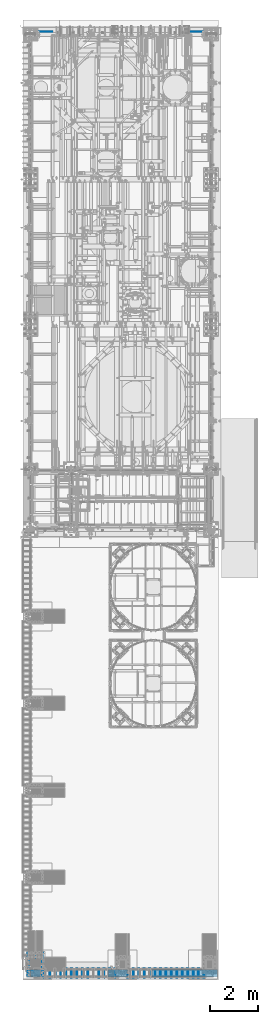
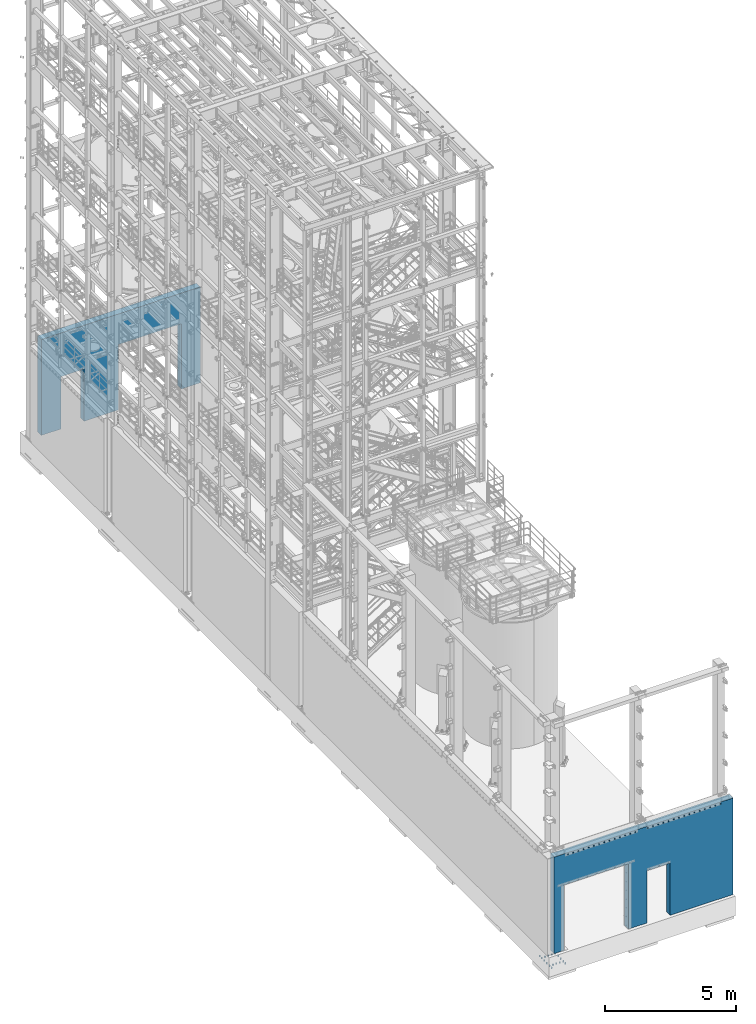
# One storey, part 1846 of 1876: 3 mechanical fasteners, 2 walls, 5 elements without a shape of their own.
"""IFC2X3 building model written with IfcOpenShell, lengths in millimetres."""

from ifc_helpers import new_model, si_unit, frame, origin_with_axes, place, context, subcontext, project, spatial, faceted_brep, source, transform, mapped, material, type_object, element, aggregate, save


model = new_model("IFC2X3")

# Units and contexts
model_context = context("Model", 3, precision=1e-05, world=origin_with_axes())
body_context = subcontext(model_context, "Body", "Model", "MODEL_VIEW")
ifc_project = project(units=[si_unit("LENGTHUNIT", "METRE", prefix="MILLI"), si_unit("AREAUNIT", "SQUARE_METRE"), si_unit("VOLUMEUNIT", "CUBIC_METRE"), si_unit("MASSUNIT", "GRAM", prefix="KILO"), si_unit("TIMEUNIT", "SECOND"), si_unit("PLANEANGLEUNIT", "RADIAN"), si_unit("SOLIDANGLEUNIT", "STERADIAN"), si_unit("THERMODYNAMICTEMPERATUREUNIT", "DEGREE_CELSIUS"), si_unit("LUMINOUSINTENSITYUNIT", "LUMEN")], contexts=[model_context])

# Site, building, storey
site_placement = place(None, origin_with_axes())
site = spatial("IfcSite", under=ifc_project, at=site_placement, CompositionType="ELEMENT")
building_placement = place(site_placement, origin_with_axes())
building = spatial("IfcBuilding", under=site, at=building_placement, Name="Undefined", CompositionType="ELEMENT")
storey_placement = place(building_placement, origin_with_axes())
storey = spatial("IfcBuildingStorey", under=building, at=storey_placement, Name="Undefined", CompositionType="ELEMENT", Elevation=0.0)

# Assembly, wall
assembly_1_placement = place(storey_placement, origin_with_axes())
assembly_1 = element("IfcElementAssembly", 1, at=assembly_1_placement, inside=storey, Name="WALL", AssemblyPlace="NOTDEFINED", PredefinedType="REINFORCEMENT_UNIT")
ifc_material_1 = material(Name="CONCRETE/5000")
wall_type_1 = type_object("IfcWallType", PredefinedType="NOTDEFINED")
wall_1_placement = place(assembly_1_placement, frame((292.100012207029, 13863.6375, 2235.2), z_axis=(0.0, 0.0, 1.0), x_axis=(1.0, 0.0, 0.0)))
wall_1 = element("IfcWall", 2, at=wall_1_placement, type_object=wall_type_1, material=ifc_material_1, Name="WALL", context=body_context, shape_type="Brep", body=[
    faceted_brep([(876.299987792969, -147.637500000001, -2235.2), (876.299987792969, 147.637500000001, -2235.2), (876.299987792969, 147.637500000001, 203.19990234375), (876.299987792969, -147.637500000001, 203.19990234375), (1892.29998779297, -147.637500000001, 203.19990234375), (1892.29998779297, 147.637500000001, 203.19990234375), (1892.29998779297, 147.637500000001, -2235.2), (1892.29998779297, -147.637500000001, -2235.2), (0.0, -147.637500000001, -2235.2), (0.0, -147.637500000001, 2235.2), (0.0, 147.637500000001, 2235.2), (0.0, 147.637500000001, -2235.2), (7010.39998779297, -147.637500000001, 2235.2), (7010.39998779297, 147.637500000001, 2235.2), (7010.39998779297, -147.637500000001, -2235.2), (7010.39998779297, 147.637500000001, -2235.2), (6170.61253662109, -147.637500000001, -2235.2), (6170.61253662109, 147.637500000001, -2235.2), (6170.61253662109, -147.637500000001, 812.8), (6170.61253662109, 147.637500000001, 812.8), (3405.18748779297, -147.637500000001, 812.8), (3405.18748779297, 147.637500000001, 812.8), (3405.18748779297, -147.637500000001, -2235.2), (3405.18748779297, 147.637500000001, -2235.2)], [[[0, 1, 2, 3]], [[4, 5, 6, 7]], [[3, 2, 5, 4]], [[8, 9, 10, 11]], [[10, 9, 12, 13]], [[12, 14, 15, 13]], [[15, 14, 16, 17]], [[18, 19, 17, 16]], [[20, 21, 19, 18]], [[22, 23, 21, 20]], [[23, 22, 7, 6]], [[1, 11, 10, 13, 15, 17, 19, 21, 23, 6, 5, 2]], [[8, 11, 1, 0]], [[22, 20, 18, 16, 14, 12, 9, 8, 0, 3, 4, 7]]]),
])
aggregate(assembly_1, [wall_1])

assembly_2_placement = place(storey_placement, origin_with_axes())
assembly_2 = element("IfcElementAssembly", 3, at=assembly_2_placement, inside=storey, Name="WALL", AssemblyPlace="NOTDEFINED", PredefinedType="REINFORCEMENT_UNIT")
wall_type_2 = type_object("IfcWallType", PredefinedType="NOTDEFINED")
wall_2_placement = place(assembly_2_placement, frame((3.17499999999995, -25776.2375, 2247.9), z_axis=(0.0, 0.0, 1.0), x_axis=(1.0, 0.0, 0.0)))
wall_2 = element("IfcWall", 4, at=wall_2_placement, type_object=wall_type_2, material=ifc_material_1, Name="WALL", context=body_context, shape_type="Brep", body=[
    faceted_brep([(4098.925, -147.637500000001, -2247.9), (4098.925, 147.637500000001, -2247.9), (4098.925, 147.637500000001, 190.49990234375), (4098.925, -147.637500000001, 190.49990234375), (5114.925, -147.637500000001, 190.49990234375), (5114.925, 147.637500000001, 190.49990234375), (5114.925, 147.637500000001, -2247.9), (5114.925, -147.637500000001, -2247.9), (3273.42504882812, -147.637500000001, 800.1), (3273.42504882812, 147.637500000001, 800.1), (3273.42504882812, 147.637500000001, -2247.9), (3273.42504882812, -147.637500000001, -2247.9), (428.625, -147.637500000001, 800.1), (428.625, 147.637500000001, 800.1), (428.625, -147.637500000001, -2247.9), (428.625, 147.637500000001, -2247.9), (0.0, -147.637500000001, -2247.9), (0.0, 147.637500000001, -2247.9), (0.0, -147.637500000001, 2247.9), (0.0, 147.637500000001, 2247.9), (7883.5248046875, -147.637500000001, 2247.9), (7883.5248046875, 147.637500000001, 2247.9), (7883.5248046875, -147.637500000001, -2247.9), (7883.5248046875, 147.637500000001, -2247.9)], [[[0, 1, 2, 3]], [[4, 5, 6, 7]], [[3, 2, 5, 4]], [[8, 9, 10, 11]], [[12, 13, 9, 8]], [[14, 15, 13, 12]], [[16, 17, 15, 14]], [[16, 18, 19, 17]], [[19, 18, 20, 21]], [[20, 22, 23, 21]], [[23, 22, 7, 6]], [[1, 10, 9, 13, 15, 17, 19, 21, 23, 6, 5, 2]], [[11, 10, 1, 0]], [[22, 20, 18, 16, 14, 12, 8, 11, 0, 3, 4, 7]]]),
])
aggregate(assembly_2, [wall_2])

# Assembly, mechanical fastener
assembly_3_placement = place(storey_placement, origin_with_axes())
assembly_3 = element("IfcElementAssembly", 5, at=assembly_3_placement, inside=storey, Name="PLATE", AssemblyPlace="NOTDEFINED", PredefinedType="RIGID_FRAME")
ifc_material_2 = material(Name="Undefined")
mechanical_fastener_type = type_object("IfcMechanicalFastenerType", Name="Bolt assembly")
shared_shape_1 = source(origin_with_axes(), body_context, "Body", "Brep", [
    faceted_brep([(16.4977843825769, -330.199999809267, 0.0), (8.24889219128843, -330.199999809267, 14.2875003814697), (-8.24889219128842, -330.199999809267, 14.2875003814697), (-16.4977843825769, -330.199999809267, 2.02039588371459e-15), (-8.24889219128844, -330.199999809267, -14.2875003814697), (8.24889219128842, -330.199999809267, -14.2875003814697), (8.24889219128842, -317.500000000001, -14.2875003814697), (-8.24889219128844, -317.500000000001, -14.2875003814697), (-16.4977843825769, -317.500000000001, 2.02039588371459e-15), (-8.24889219128842, -317.500000000001, 14.2875003814697), (8.24889219128843, -317.500000000001, 14.2875003814697), (16.4977843825769, -317.500000000001, 0.0), (9.52499961853027, -317.500000000001, 0.0), (8.24889164068414, -317.500000000001, 4.76249980926542), (4.76249980926457, -317.500000000001, 8.24889164068463), (-9.87109982941227e-13, -317.500000000001, 9.52499961853027), (-4.76249980926627, -317.500000000001, 8.24889164068365), (-8.24889164068512, -317.500000000001, 4.76249980926371), (-9.52499961853027, -317.500000000001, -1.97421996588245e-12), (-8.24889164068315, -317.500000000001, -4.76249980926713), (-4.76249980926286, -317.500000000001, -8.24889164068562), (2.95075507493764e-12, -317.500000000001, -9.52499961853027), (4.76249980926798, -317.500000000001, -8.24889164068266), (8.24889164068611, -317.500000000001, -4.76249980926201), (8.24889164068611, 38.1000007629366, -4.76249980926201), (4.76249980926798, 38.1000007629366, -8.24889164068266), (2.95075507493764e-12, 38.1000007629366, -9.52499961853027), (-4.76249980926286, 38.1000007629366, -8.24889164068562), (-8.24889164068315, 38.1000007629366, -4.76249980926713), (-9.52499961853027, 38.1000007629366, -1.97421996588245e-12), (-8.24889164068512, 38.1000007629366, 4.76249980926371), (-4.76249980926627, 38.1000007629366, 8.24889164068365), (-9.87109982941227e-13, 38.1000007629366, 9.52499961853027), (4.76249980926457, 38.1000007629366, 8.24889164068463), (8.24889164068414, 38.1000007629366, 4.76249980926542), (9.52499961853027, 38.1000007629366, 0.0), (18.6531505584717, 12.7, 0.0), (16.154102244252, 12.7, 9.3265752792364), (9.32657527923473, 12.7, 16.154102244253), (-1.93309310939524e-12, 12.7, 18.6531505584717), (-9.32657527923807, 12.7, 16.1541022442511), (-16.154102244254, 12.7, 9.32657527923306), (-18.6531505584717, 12.7, -3.86618621879047e-12), (-16.1541022442501, 12.7, -9.32657527923974), (-9.32657527923138, 12.7, -16.1541022442549), (5.77857017095389e-12, 12.7, -18.6531505584717), (9.32657527924141, 12.7, -16.1541022442491), (16.1541022442559, 12.7, -9.32657527922971), (16.1541022442559, 15.8749999523163, -9.32657527922971), (9.32657527924141, 15.8749999523163, -16.1541022442491), (5.77857017095389e-12, 15.8749999523163, -18.6531505584717), (-9.32657527923138, 15.8749999523163, -16.1541022442549), (-16.1541022442501, 15.8749999523163, -9.32657527923974), (-18.6531505584717, 15.8749999523163, -3.86618621879047e-12), (-16.154102244254, 15.8749999523163, 9.32657527923306), (-9.32657527923807, 15.8749999523163, 16.1541022442511), (-1.93309310939524e-12, 15.8749999523163, 18.6531505584717), (9.32657527923473, 15.8749999523163, 16.154102244253), (16.154102244252, 15.8749999523163, 9.3265752792364), (18.6531505584717, 15.8749999523163, 0.0), (16.4977843825769, 15.8749999523111, 0.0), (8.24889219128843, 15.8749999523111, 14.2875003814697), (-8.24889219128842, 15.8749999523111, 14.2875003814697), (-16.4977843825769, 15.8749999523111, 2.02039588371459e-15), (-8.24889219128844, 15.8749999523111, -14.2875003814697), (8.24889219128842, 15.8749999523111, -14.2875003814697), (8.24889219128842, 28.5749997615762, -14.2875003814697), (-8.24889219128844, 28.5749997615762, -14.2875003814697), (-16.4977843825769, 28.5749997615762, 2.02039588371459e-15), (-8.24889219128842, 28.5749997615762, 14.2875003814697), (8.24889219128843, 28.5749997615762, 14.2875003814697), (16.4977843825769, 28.5749997615762, 0.0)], [[[0, 1, 2, 3, 4, 5]], [[6, 7, 8, 9, 10, 11]], [[0, 11, 10, 1]], [[1, 10, 9, 2]], [[2, 9, 8, 3]], [[3, 8, 7, 4]], [[4, 7, 6, 5]], [[5, 6, 11, 0]], [[12, 13, 14, 15, 16, 17, 18, 19, 20, 21, 22, 23]], [[24, 25, 26, 27, 28, 29, 30, 31, 32, 33, 34, 35]], [[12, 35, 34, 13]], [[13, 34, 33, 14]], [[14, 33, 32, 15]], [[15, 32, 31, 16]], [[16, 31, 30, 17]], [[17, 30, 29, 18]], [[18, 29, 28, 19]], [[19, 28, 27, 20]], [[20, 27, 26, 21]], [[21, 26, 25, 22]], [[22, 25, 24, 23]], [[23, 24, 35, 12]], [[36, 37, 38, 39, 40, 41, 42, 43, 44, 45, 46, 47]], [[48, 49, 50, 51, 52, 53, 54, 55, 56, 57, 58, 59]], [[36, 59, 58, 37]], [[37, 58, 57, 38]], [[38, 57, 56, 39]], [[39, 56, 55, 40]], [[40, 55, 54, 41]], [[41, 54, 53, 42]], [[42, 53, 52, 43]], [[43, 52, 51, 44]], [[44, 51, 50, 45]], [[45, 50, 49, 46]], [[46, 49, 48, 47]], [[47, 48, 59, 36]], [[60, 61, 62, 63, 64, 65]], [[66, 67, 68, 69, 70, 71]], [[60, 71, 70, 61]], [[61, 70, 69, 62]], [[62, 69, 68, 63]], [[63, 68, 67, 64]], [[64, 67, 66, 65]], [[65, 66, 71, 60]]]),
    faceted_brep([(11.90625, -0.100000000005002, 0.0), (10.3111149638083, -0.100000000005002, 5.95312500000036), (5.95312499999929, -0.100000000005002, 10.3111149638089), (-1.23388752809288e-12, -0.100000000005002, 11.90625), (-5.95312500000142, -0.100000000005002, 10.3111149638077), (-10.3111149638095, -0.100000000005002, 5.95312499999822), (-11.90625, -0.100000000005002, -2.46777505618577e-12), (-10.311114963807, -0.100000000005002, -5.95312500000249), (-5.95312499999716, -0.100000000005002, -10.3111149638101), (3.68844399139171e-12, -0.100000000005002, -11.90625), (5.95312500000355, -0.100000000005002, -10.3111149638064), (10.3111149638107, -0.100000000005002, -5.95312499999609), (10.3111149638107, 12.6999999999948, -5.95312499999609), (5.95312500000355, 12.6999999999948, -10.3111149638064), (3.68844399139171e-12, 12.6999999999948, -11.90625), (-5.95312499999716, 12.6999999999948, -10.3111149638101), (-10.311114963807, 12.6999999999948, -5.95312500000249), (-11.90625, 12.6999999999948, -2.46777505618577e-12), (-10.3111149638095, 12.6999999999948, 5.95312499999822), (-5.95312500000142, 12.6999999999948, 10.3111149638077), (-1.23388752809288e-12, 12.6999999999948, 11.90625), (5.95312499999929, 12.6999999999948, 10.3111149638089), (10.3111149638083, 12.6999999999948, 5.95312500000036), (11.90625, 12.6999999999948, 0.0), (11.90625, -304.800000000002, 0.0), (10.3111149638083, -304.800000000002, 5.95312500000036), (5.95312499999929, -304.800000000002, 10.3111149638089), (-1.23388752809288e-12, -304.800000000002, 11.90625), (-5.95312500000142, -304.800000000002, 10.3111149638077), (-10.3111149638095, -304.800000000002, 5.95312499999822), (-11.90625, -304.800000000002, -2.46777505618577e-12), (-10.311114963807, -304.800000000002, -5.95312500000249), (-5.95312499999716, -304.800000000002, -10.3111149638101), (3.68844399139171e-12, -304.800000000002, -11.90625), (5.95312500000355, -304.800000000002, -10.3111149638064), (10.3111149638107, -304.800000000002, -5.95312499999609), (10.3111149638107, -296.862000000002, -5.95312499999609), (5.95312500000355, -296.862000000002, -10.3111149638064), (3.68844399139171e-12, -296.862000000002, -11.90625), (-5.95312499999716, -296.862000000002, -10.3111149638101), (-10.311114963807, -296.862000000002, -5.95312500000249), (-11.90625, -296.862000000002, -2.46777505618577e-12), (-10.3111149638095, -296.862000000002, 5.95312499999822), (-5.95312500000142, -296.862000000002, 10.3111149638077), (-1.23388752809288e-12, -296.862000000002, 11.90625), (5.95312499999929, -296.862000000002, 10.3111149638089), (10.3111149638083, -296.862000000002, 5.95312500000036), (11.90625, -296.862000000002, 0.0), (11.90625, -317.400000000001, 0.0), (10.3111149638083, -317.400000000001, 5.95312500000036), (5.95312499999929, -317.400000000001, 10.3111149638089), (-1.23388752809288e-12, -317.400000000001, 11.90625), (-5.95312500000142, -317.400000000001, 10.3111149638077), (-10.3111149638095, -317.400000000001, 5.95312499999822), (-11.90625, -317.400000000001, -2.46777505618577e-12), (-10.311114963807, -317.400000000001, -5.95312500000249), (-5.95312499999716, -317.400000000001, -10.3111149638101), (3.68844399139171e-12, -317.400000000001, -11.90625), (5.95312500000355, -317.400000000001, -10.3111149638064), (10.3111149638107, -317.400000000001, -5.95312499999609), (10.3111149638107, -304.700000000001, -5.95312499999609), (5.95312500000355, -304.700000000001, -10.3111149638064), (3.68844399139171e-12, -304.700000000001, -11.90625), (-5.95312499999716, -304.700000000001, -10.3111149638101), (-10.311114963807, -304.700000000001, -5.95312500000249), (-11.90625, -304.700000000001, -2.46777505618577e-12), (-10.3111149638095, -304.700000000001, 5.95312499999822), (-5.95312500000142, -304.700000000001, 10.3111149638077), (-1.23388752809288e-12, -304.700000000001, 11.90625), (5.95312499999929, -304.700000000001, 10.3111149638089), (10.3111149638083, -304.700000000001, 5.95312500000036), (11.90625, -304.700000000001, 0.0)], [[[0, 1, 2, 3, 4, 5, 6, 7, 8, 9, 10, 11]], [[12, 13, 14, 15, 16, 17, 18, 19, 20, 21, 22, 23]], [[0, 23, 22, 1]], [[1, 22, 21, 2]], [[2, 21, 20, 3]], [[3, 20, 19, 4]], [[4, 19, 18, 5]], [[5, 18, 17, 6]], [[6, 17, 16, 7]], [[7, 16, 15, 8]], [[8, 15, 14, 9]], [[9, 14, 13, 10]], [[10, 13, 12, 11]], [[11, 12, 23, 0]], [[24, 25, 26, 27, 28, 29, 30, 31, 32, 33, 34, 35]], [[36, 37, 38, 39, 40, 41, 42, 43, 44, 45, 46, 47]], [[24, 47, 46, 25]], [[25, 46, 45, 26]], [[26, 45, 44, 27]], [[27, 44, 43, 28]], [[28, 43, 42, 29]], [[29, 42, 41, 30]], [[30, 41, 40, 31]], [[31, 40, 39, 32]], [[32, 39, 38, 33]], [[33, 38, 37, 34]], [[34, 37, 36, 35]], [[35, 36, 47, 24]], [[48, 49, 50, 51, 52, 53, 54, 55, 56, 57, 58, 59]], [[60, 61, 62, 63, 64, 65, 66, 67, 68, 69, 70, 71]], [[48, 71, 70, 49]], [[49, 70, 69, 50]], [[50, 69, 68, 51]], [[51, 68, 67, 52]], [[52, 67, 66, 53]], [[53, 66, 65, 54]], [[54, 65, 64, 55]], [[55, 64, 63, 56]], [[56, 63, 62, 57]], [[57, 62, 61, 58]], [[58, 61, 60, 59]], [[59, 60, 71, 48]]]),
])
mechanical_fastener_1_placement = place(assembly_3_placement, frame((600.073752879375, -25923.875, 4432.3), z_axis=(0.0, 0.0, -1.0), x_axis=(1.0, 0.0, 0.0)))
mechanical_fastener_1 = element("IfcMechanicalFastener", 6, at=mechanical_fastener_1_placement, type_object=mechanical_fastener_type, material=ifc_material_2, Name="Bolt assembly", NominalDiameter=19.0499992370605, NominalLength=355.600006103516, context=body_context, shape_type="MappedRepresentation", body=[
    mapped(shared_shape_1, transform((0.0, 0.0, 0.0))),
    mapped(shared_shape_1, transform((228.600006103516, 0.0, 0.0))),
    mapped(shared_shape_1, transform((457.200012207031, 0.0, 0.0))),
    mapped(shared_shape_1, transform((685.799987792969, 0.0, 0.0))),
    mapped(shared_shape_1, transform((914.400024414062, 0.0, 0.0))),
    mapped(shared_shape_1, transform((1143.0, 0.0, 0.0))),
    mapped(shared_shape_1, transform((1371.59997558594, 0.0, 0.0))),
    mapped(shared_shape_1, transform((1600.20007324219, 0.0, 0.0))),
    mapped(shared_shape_1, transform((1828.80004882812, 0.0, 0.0))),
    mapped(shared_shape_1, transform((2057.40014648438, 0.0, 0.0))),
    mapped(shared_shape_1, transform((2286.0, 0.0, 0.0))),
    mapped(shared_shape_1, transform((2514.60009765625, 0.0, 0.0))),
    mapped(shared_shape_1, transform((2743.19995117188, 0.0, 0.0))),
    mapped(shared_shape_1, transform((2971.80004882812, 0.0, 0.0))),
])
aggregate(assembly_3, [mechanical_fastener_1])

assembly_4_placement = place(storey_placement, origin_with_axes())
assembly_4 = element("IfcElementAssembly", 7, at=assembly_4_placement, inside=storey, Name="PLATE", AssemblyPlace="NOTDEFINED", PredefinedType="RIGID_FRAME")
shared_shape_2 = source(origin_with_axes(), body_context, "Body", "Brep", [
    faceted_brep([(16.4977843825769, -339.724999809268, 0.0), (8.24889219128843, -339.724999809268, 14.2875003814697), (-8.24889219128842, -339.724999809268, 14.2875003814697), (-16.4977843825769, -339.724999809268, 2.02039588371459e-15), (-8.24889219128844, -339.724999809268, -14.2875003814697), (8.24889219128842, -339.724999809268, -14.2875003814697), (8.24889219128842, -327.025000000003, -14.2875003814697), (-8.24889219128844, -327.025000000003, -14.2875003814697), (-16.4977843825769, -327.025000000003, 2.02039588371459e-15), (-8.24889219128842, -327.025000000003, 14.2875003814697), (8.24889219128843, -327.025000000003, 14.2875003814697), (16.4977843825769, -327.025000000003, 0.0), (9.52499961853027, -327.025000000003, 0.0), (8.24889164068414, -327.025000000003, 4.76249980926542), (4.76249980926457, -327.025000000003, 8.24889164068463), (-9.87109982941227e-13, -327.025000000003, 9.52499961853027), (-4.76249980926627, -327.025000000003, 8.24889164068365), (-8.24889164068512, -327.025000000003, 4.76249980926371), (-9.52499961853027, -327.025000000003, -1.97421996588245e-12), (-8.24889164068315, -327.025000000003, -4.76249980926713), (-4.76249980926286, -327.025000000003, -8.24889164068562), (2.95075507493764e-12, -327.025000000003, -9.52499961853027), (4.76249980926798, -327.025000000003, -8.24889164068266), (8.24889164068611, -327.025000000003, -4.76249980926201), (8.24889164068611, 28.5750007629384, -4.76249980926201), (4.76249980926798, 28.5750007629384, -8.24889164068266), (2.95075507493764e-12, 28.5750007629384, -9.52499961853027), (-4.76249980926286, 28.5750007629384, -8.24889164068562), (-8.24889164068315, 28.5750007629384, -4.76249980926713), (-9.52499961853027, 28.5750007629384, -1.97421996588245e-12), (-8.24889164068512, 28.5750007629384, 4.76249980926371), (-4.76249980926627, 28.5750007629384, 8.24889164068365), (-9.87109982941227e-13, 28.5750007629384, 9.52499961853027), (4.76249980926457, 28.5750007629384, 8.24889164068463), (8.24889164068414, 28.5750007629384, 4.76249980926542), (9.52499961853027, 28.5750007629384, 0.0), (18.6531505584717, 3.175, 0.0), (16.154102244252, 3.175, 9.3265752792364), (9.32657527923473, 3.175, 16.154102244253), (-1.93309310939524e-12, 3.175, 18.6531505584717), (-9.32657527923807, 3.175, 16.1541022442511), (-16.154102244254, 3.175, 9.32657527923306), (-18.6531505584717, 3.175, -3.86618621879047e-12), (-16.1541022442501, 3.175, -9.32657527923974), (-9.32657527923138, 3.175, -16.1541022442549), (5.77857017095389e-12, 3.175, -18.6531505584717), (9.32657527924141, 3.175, -16.1541022442491), (16.1541022442559, 3.175, -9.32657527922971), (16.1541022442559, 6.34999995231628, -9.32657527922971), (9.32657527924141, 6.34999995231628, -16.1541022442491), (5.77857017095389e-12, 6.34999995231628, -18.6531505584717), (-9.32657527923138, 6.34999995231628, -16.1541022442549), (-16.1541022442501, 6.34999995231628, -9.32657527923974), (-18.6531505584717, 6.34999995231628, -3.86618621879047e-12), (-16.154102244254, 6.34999995231628, 9.32657527923306), (-9.32657527923807, 6.34999995231628, 16.1541022442511), (-1.93309310939524e-12, 6.34999995231628, 18.6531505584717), (9.32657527923473, 6.34999995231628, 16.154102244253), (16.154102244252, 6.34999995231628, 9.3265752792364), (18.6531505584717, 6.34999995231628, 0.0), (16.4977843825769, 6.35000020069373, 0.0), (8.24889219128843, 6.35000020069373, 14.2875003814697), (-8.24889219128842, 6.35000020069373, 14.2875003814697), (-16.4977843825769, 6.35000020069373, 2.02039588371459e-15), (-8.24889219128844, 6.35000020069373, -14.2875003814697), (8.24889219128842, 6.35000020069373, -14.2875003814697), (8.24889219128842, 19.0500000099589, -14.2875003814697), (-8.24889219128844, 19.0500000099589, -14.2875003814697), (-16.4977843825769, 19.0500000099589, 2.02039588371459e-15), (-8.24889219128842, 19.0500000099589, 14.2875003814697), (8.24889219128843, 19.0500000099589, 14.2875003814697), (16.4977843825769, 19.0500000099589, 0.0)], [[[0, 1, 2, 3, 4, 5]], [[6, 7, 8, 9, 10, 11]], [[0, 11, 10, 1]], [[1, 10, 9, 2]], [[2, 9, 8, 3]], [[3, 8, 7, 4]], [[4, 7, 6, 5]], [[5, 6, 11, 0]], [[12, 13, 14, 15, 16, 17, 18, 19, 20, 21, 22, 23]], [[24, 25, 26, 27, 28, 29, 30, 31, 32, 33, 34, 35]], [[12, 35, 34, 13]], [[13, 34, 33, 14]], [[14, 33, 32, 15]], [[15, 32, 31, 16]], [[16, 31, 30, 17]], [[17, 30, 29, 18]], [[18, 29, 28, 19]], [[19, 28, 27, 20]], [[20, 27, 26, 21]], [[21, 26, 25, 22]], [[22, 25, 24, 23]], [[23, 24, 35, 12]], [[36, 37, 38, 39, 40, 41, 42, 43, 44, 45, 46, 47]], [[48, 49, 50, 51, 52, 53, 54, 55, 56, 57, 58, 59]], [[36, 59, 58, 37]], [[37, 58, 57, 38]], [[38, 57, 56, 39]], [[39, 56, 55, 40]], [[40, 55, 54, 41]], [[41, 54, 53, 42]], [[42, 53, 52, 43]], [[43, 52, 51, 44]], [[44, 51, 50, 45]], [[45, 50, 49, 46]], [[46, 49, 48, 47]], [[47, 48, 59, 36]], [[60, 61, 62, 63, 64, 65]], [[66, 67, 68, 69, 70, 71]], [[60, 71, 70, 61]], [[61, 70, 69, 62]], [[62, 69, 68, 63]], [[63, 68, 67, 64]], [[64, 67, 66, 65]], [[65, 66, 71, 60]]]),
    faceted_brep([(11.90625, -9.6250000000101, 0.0), (10.3111149638083, -9.6250000000101, 5.95312500000036), (5.95312499999929, -9.6250000000101, 10.3111149638089), (-1.23388752809288e-12, -9.6250000000101, 11.90625), (-5.95312500000142, -9.6250000000101, 10.3111149638077), (-10.3111149638095, -9.6250000000101, 5.95312499999822), (-11.90625, -9.6250000000101, -2.46777505618577e-12), (-10.311114963807, -9.6250000000101, -5.95312500000249), (-5.95312499999716, -9.6250000000101, -10.3111149638101), (3.68844399139171e-12, -9.6250000000101, -11.90625), (5.95312500000355, -9.6250000000101, -10.3111149638064), (10.3111149638107, -9.6250000000101, -5.95312499999609), (10.3111149638107, 3.17499999998972, -5.95312499999609), (5.95312500000355, 3.17499999998972, -10.3111149638064), (3.68844399139171e-12, 3.17499999998972, -11.90625), (-5.95312499999716, 3.17499999998972, -10.3111149638101), (-10.311114963807, 3.17499999998972, -5.95312500000249), (-11.90625, 3.17499999998972, -2.46777505618577e-12), (-10.3111149638095, 3.17499999998972, 5.95312499999822), (-5.95312500000142, 3.17499999998972, 10.3111149638077), (-1.23388752809288e-12, 3.17499999998972, 11.90625), (5.95312499999929, 3.17499999998972, 10.3111149638089), (10.3111149638083, 3.17499999998972, 5.95312500000036), (11.90625, 3.17499999998972, 0.0), (11.90625, -314.325000000003, 0.0), (10.3111149638083, -314.325000000003, 5.95312500000036), (5.95312499999929, -314.325000000003, 10.3111149638089), (-1.23388752809288e-12, -314.325000000003, 11.90625), (-5.95312500000142, -314.325000000003, 10.3111149638077), (-10.3111149638095, -314.325000000003, 5.95312499999822), (-11.90625, -314.325000000003, -2.46777505618577e-12), (-10.311114963807, -314.325000000003, -5.95312500000249), (-5.95312499999716, -314.325000000003, -10.3111149638101), (3.68844399139171e-12, -314.325000000003, -11.90625), (5.95312500000355, -314.325000000003, -10.3111149638064), (10.3111149638107, -314.325000000003, -5.95312499999609), (10.3111149638107, -306.387000000003, -5.95312499999609), (5.95312500000355, -306.387000000003, -10.3111149638064), (3.68844399139171e-12, -306.387000000003, -11.90625), (-5.95312499999716, -306.387000000003, -10.3111149638101), (-10.311114963807, -306.387000000003, -5.95312500000249), (-11.90625, -306.387000000003, -2.46777505618577e-12), (-10.3111149638095, -306.387000000003, 5.95312499999822), (-5.95312500000142, -306.387000000003, 10.3111149638077), (-1.23388752809288e-12, -306.387000000003, 11.90625), (5.95312499999929, -306.387000000003, 10.3111149638089), (10.3111149638083, -306.387000000003, 5.95312500000036), (11.90625, -306.387000000003, 0.0), (11.90625, -326.925000000003, 0.0), (10.3111149638083, -326.925000000003, 5.95312500000036), (5.95312499999929, -326.925000000003, 10.3111149638089), (-1.23388752809288e-12, -326.925000000003, 11.90625), (-5.95312500000142, -326.925000000003, 10.3111149638077), (-10.3111149638095, -326.925000000003, 5.95312499999822), (-11.90625, -326.925000000003, -2.46777505618577e-12), (-10.311114963807, -326.925000000003, -5.95312500000249), (-5.95312499999716, -326.925000000003, -10.3111149638101), (3.68844399139171e-12, -326.925000000003, -11.90625), (5.95312500000355, -326.925000000003, -10.3111149638064), (10.3111149638107, -326.925000000003, -5.95312499999609), (10.3111149638107, -314.225000000003, -5.95312499999609), (5.95312500000355, -314.225000000003, -10.3111149638064), (3.68844399139171e-12, -314.225000000003, -11.90625), (-5.95312499999716, -314.225000000003, -10.3111149638101), (-10.311114963807, -314.225000000003, -5.95312500000249), (-11.90625, -314.225000000003, -2.46777505618577e-12), (-10.3111149638095, -314.225000000003, 5.95312499999822), (-5.95312500000142, -314.225000000003, 10.3111149638077), (-1.23388752809288e-12, -314.225000000003, 11.90625), (5.95312499999929, -314.225000000003, 10.3111149638089), (10.3111149638083, -314.225000000003, 5.95312500000036), (11.90625, -314.225000000003, 0.0)], [[[0, 1, 2, 3, 4, 5, 6, 7, 8, 9, 10, 11]], [[12, 13, 14, 15, 16, 17, 18, 19, 20, 21, 22, 23]], [[0, 23, 22, 1]], [[1, 22, 21, 2]], [[2, 21, 20, 3]], [[3, 20, 19, 4]], [[4, 19, 18, 5]], [[5, 18, 17, 6]], [[6, 17, 16, 7]], [[7, 16, 15, 8]], [[8, 15, 14, 9]], [[9, 14, 13, 10]], [[10, 13, 12, 11]], [[11, 12, 23, 0]], [[24, 25, 26, 27, 28, 29, 30, 31, 32, 33, 34, 35]], [[36, 37, 38, 39, 40, 41, 42, 43, 44, 45, 46, 47]], [[24, 47, 46, 25]], [[25, 46, 45, 26]], [[26, 45, 44, 27]], [[27, 44, 43, 28]], [[28, 43, 42, 29]], [[29, 42, 41, 30]], [[30, 41, 40, 31]], [[31, 40, 39, 32]], [[32, 39, 38, 33]], [[33, 38, 37, 34]], [[34, 37, 36, 35]], [[35, 36, 47, 24]], [[48, 49, 50, 51, 52, 53, 54, 55, 56, 57, 58, 59]], [[60, 61, 62, 63, 64, 65, 66, 67, 68, 69, 70, 71]], [[48, 71, 70, 49]], [[49, 70, 69, 50]], [[50, 69, 68, 51]], [[51, 68, 67, 52]], [[52, 67, 66, 53]], [[53, 66, 65, 54]], [[54, 65, 64, 55]], [[55, 64, 63, 56]], [[56, 63, 62, 57]], [[57, 62, 61, 58]], [[58, 61, 60, 59]], [[59, 60, 71, 48]]]),
])
mechanical_fastener_2_placement = place(assembly_4_placement, frame((4117.97499961853, -25933.4, 4432.3), z_axis=(0.0, 0.0, -1.0), x_axis=(1.0, 0.0, 0.0)))
mechanical_fastener_2 = element("IfcMechanicalFastener", 8, at=mechanical_fastener_2_placement, type_object=mechanical_fastener_type, material=ifc_material_2, Name="Bolt assembly", NominalDiameter=19.0499992370605, NominalLength=355.600006103516, context=body_context, shape_type="MappedRepresentation", body=[
    mapped(shared_shape_2, transform((0.0, 0.0, 0.0))),
    mapped(shared_shape_2, transform((228.600006103516, 0.0, 0.0))),
    mapped(shared_shape_2, transform((457.200012207031, 0.0, 0.0))),
    mapped(shared_shape_2, transform((685.799987792969, 0.0, 0.0))),
    mapped(shared_shape_2, transform((914.400024414062, 0.0, 0.0))),
    mapped(shared_shape_2, transform((1143.0, 0.0, 0.0))),
    mapped(shared_shape_2, transform((1371.59997558594, 0.0, 0.0))),
    mapped(shared_shape_2, transform((1600.20007324219, 0.0, 0.0))),
    mapped(shared_shape_2, transform((1828.80004882812, 0.0, 0.0))),
    mapped(shared_shape_2, transform((2057.40014648438, 0.0, 0.0))),
    mapped(shared_shape_2, transform((2286.0, 0.0, 0.0))),
    mapped(shared_shape_2, transform((2514.60009765625, 0.0, 0.0))),
    mapped(shared_shape_2, transform((2743.19995117188, 0.0, 0.0))),
    mapped(shared_shape_2, transform((2971.80004882812, 0.0, 0.0))),
    mapped(shared_shape_2, transform((3200.40014648437, 0.0, 0.0))),
])
aggregate(assembly_4, [mechanical_fastener_2])

assembly_5_placement = place(storey_placement, origin_with_axes())
assembly_5 = element("IfcElementAssembly", 9, at=assembly_5_placement, inside=storey, Name="PLATE", AssemblyPlace="NOTDEFINED", PredefinedType="RIGID_FRAME")
shared_shape_3 = source(origin_with_axes(), body_context, "Body", "Brep", [
    faceted_brep([(19.84375, -57.15, 0.0), (17.1851916063471, -57.15, 9.92187500000059), (9.92187499999882, -57.15, 17.1851916063481), (-2.05647921348814e-12, -57.15, 19.84375), (-9.92187500000237, -57.15, 17.1851916063461), (-17.1851916063492, -57.15, 9.92187499999704), (-19.84375, -57.15, -4.11295842697628e-12), (-17.1851916063451, -57.15, -9.92187500000415), (-9.92187499999526, -57.15, -17.1851916063502), (6.14740665231951e-12, -57.15, -19.84375), (9.92187500000592, -57.15, -17.185191606344), (17.1851916063512, -57.15, -9.92187499999348), (17.1851916063512, 0.0999999999999588, -9.92187499999348), (9.92187500000592, 0.0999999999999588, -17.185191606344), (6.14740665231951e-12, 0.0999999999999588, -19.84375), (-9.92187499999526, 0.0999999999999588, -17.1851916063502), (-17.1851916063451, 0.0999999999999588, -9.92187500000415), (-19.84375, 0.0999999999999588, -4.11295842697628e-12), (-17.1851916063492, 0.0999999999999588, 9.92187499999704), (-9.92187500000237, 0.0999999999999588, 17.1851916063461), (-2.05647921348814e-12, 0.0999999999999588, 19.84375), (9.92187499999882, 0.0999999999999588, 17.1851916063481), (17.1851916063471, 0.0999999999999588, 9.92187500000059), (19.84375, 0.0999999999999588, 0.0)], [[[0, 1, 2, 3, 4, 5, 6, 7, 8, 9, 10, 11]], [[12, 13, 14, 15, 16, 17, 18, 19, 20, 21, 22, 23]], [[0, 23, 22, 1]], [[1, 22, 21, 2]], [[2, 21, 20, 3]], [[3, 20, 19, 4]], [[4, 19, 18, 5]], [[5, 18, 17, 6]], [[6, 17, 16, 7]], [[7, 16, 15, 8]], [[8, 15, 14, 9]], [[9, 14, 13, 10]], [[10, 13, 12, 11]], [[11, 12, 23, 0]]]),
])
mechanical_fastener_3_placement = place(assembly_5_placement, frame((536.57500606537, -25399.9999631503, -641.349999999995), z_axis=(0.0, 1.0, 0.0), x_axis=(-1.0, 0.0, 0.0)))
mechanical_fastener_3 = element("IfcMechanicalFastener", 10, at=mechanical_fastener_3_placement, type_object=mechanical_fastener_type, material=ifc_material_2, Name="Bolt assembly", NominalDiameter=38.0999984741211, NominalLength=57.1500015258789, context=body_context, shape_type="MappedRepresentation", body=[
    mapped(shared_shape_3, transform((0.0, 0.0, -457.200012207031))),
    mapped(shared_shape_3, transform((0.0, 0.0, -304.8))),
    mapped(shared_shape_3, transform((0.0, 0.0, -101.599998474121))),
    mapped(shared_shape_3, transform((0.0, 0.0, 101.599998474121))),
    mapped(shared_shape_3, transform((0.0, 0.0, 304.8))),
    mapped(shared_shape_3, transform((0.0, 0.0, 457.200012207031))),
    mapped(shared_shape_3, transform((152.399993896484, 0.0, -304.799987792969))),
    mapped(shared_shape_3, transform((152.399993896484, 0.0, 304.799987792969))),
    mapped(shared_shape_3, transform((304.799987792969, 0.0, -304.799987792969))),
    mapped(shared_shape_3, transform((304.799987792969, 0.0, 304.799987792969))),
    mapped(shared_shape_3, transform((457.200012207031, 0.0, -304.799987792969))),
    mapped(shared_shape_3, transform((457.200012207031, 0.0, 304.799987792969))),
    mapped(shared_shape_3, transform((609.599975585938, 0.0, -457.200012207031))),
    mapped(shared_shape_3, transform((609.599975585938, 0.0, -304.799987792969))),
    mapped(shared_shape_3, transform((609.599975585938, 0.0, -101.599998474121))),
    mapped(shared_shape_3, transform((609.599975585938, 0.0, 457.200012207031))),
    mapped(shared_shape_3, transform((609.599975585938, 0.0, 304.799987792969))),
    mapped(shared_shape_3, transform((609.599975585938, 0.0, 101.599998474121))),
])
aggregate(assembly_5, [mechanical_fastener_3])

save(model, "model.ifc")
